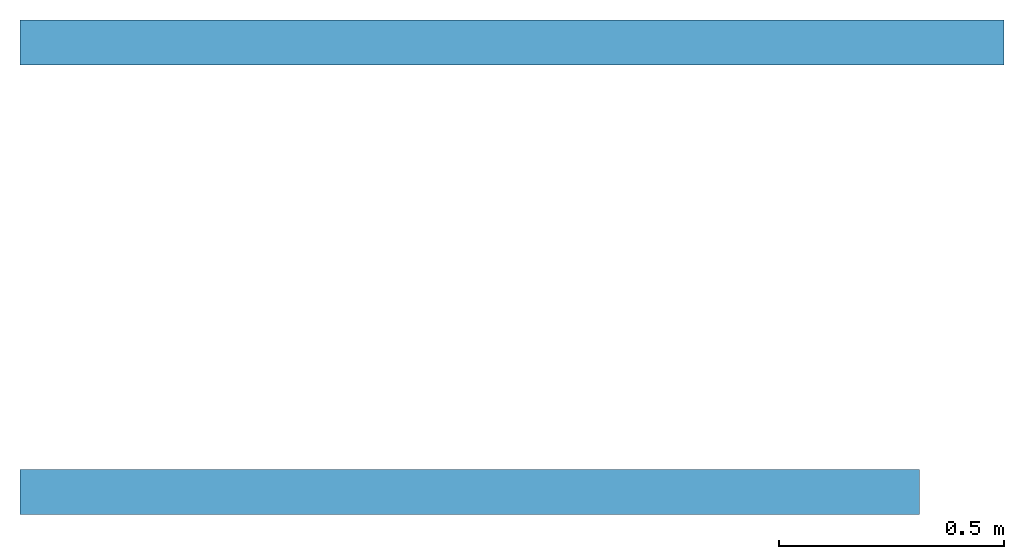
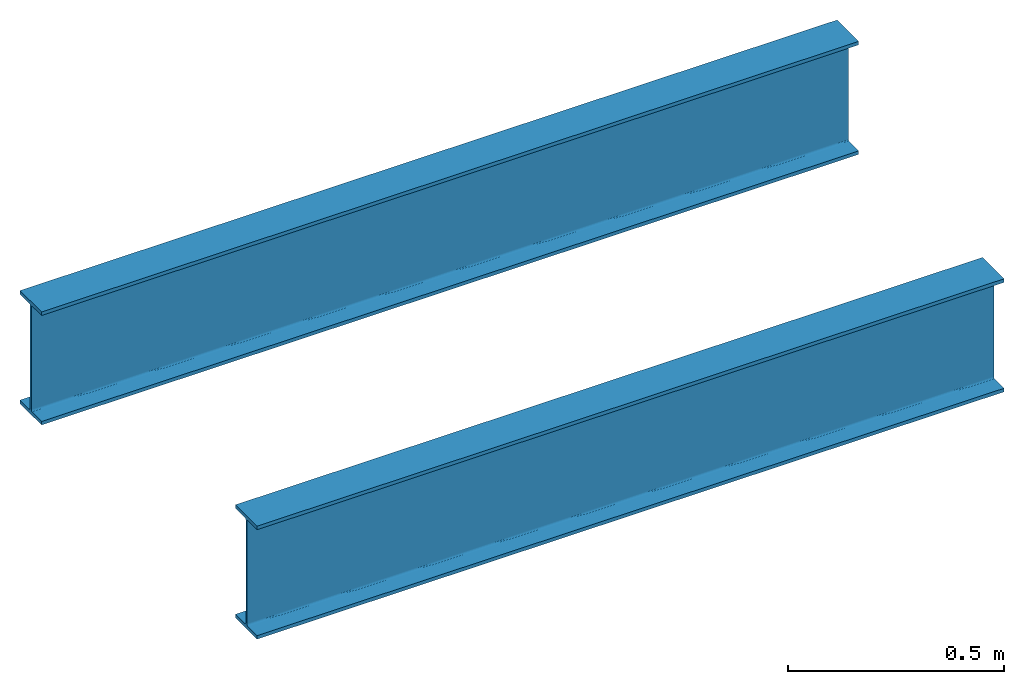
# One storey: 2 beams.
"""IFC4 building model written with IfcOpenShell, lengths in metres."""

from ifc_helpers import new_model, si_unit, frame, origin_with_axes, place, context, subcontext, project, spatial, i_section, extrude, material, material_profile, profile_set, profile_usage, type_object, element, save


model = new_model("IFC4")

# Units and contexts
model_context = context("Model", 3, precision=1e-05, world=origin_with_axes())
plan_context = context("Plan", 2, precision=1e-05, world=origin_with_axes())
body_context = subcontext(model_context, "Body", "Model", "MODEL_VIEW")
ifc_project = project(units=[si_unit("LENGTHUNIT", "METRE"), si_unit("AREAUNIT", "SQUARE_METRE"), si_unit("VOLUMEUNIT", "CUBIC_METRE")], contexts=[model_context, plan_context])

# Site, building, storey
site_placement = place(None, origin_with_axes())
site = spatial("IfcSite", under=ifc_project, at=site_placement)
building_placement = place(site_placement, origin_with_axes())
building = spatial("IfcBuilding", under=site, at=building_placement, Name="Building")
storey_placement = place(building_placement, origin_with_axes())
storey = spatial("IfcBuildingStorey", under=building, at=storey_placement, Name="Storey")

# Beams
ifc_material = material(Name="test material")
ifc_material_profile = material_profile(ifc_material, i_section(OverallWidth=0.100000001490116, OverallDepth=0.319999992847443, WebThickness=0.00499999988824129, FlangeThickness=0.00999999977648258, FilletRadius=0.00499999988824129))
ifc_profile_set = profile_set([ifc_material_profile])
ifc_profile_usage = profile_usage(ifc_profile_set)
beam_type = type_object("IfcBeamType", Name="DEMO1", material=ifc_profile_set)
beam_1_placement = place(storey_placement, frame((0.0, 0.0, 0.0), z_axis=(1.0, 4.37113882867379e-08, -4.37113882867379e-08), x_axis=(-4.37113882867379e-08, 1.0, 0.0)))
element("IfcBeam", 1, at=beam_1_placement, inside=storey, type_object=beam_type, material=ifc_profile_usage, Name="Beam", context=body_context, shape_type="SweptSolid", body=[
    extrude(i_section(OverallWidth=0.100000001490116, OverallDepth=0.319999992847443, WebThickness=0.00499999988824129, FlangeThickness=0.00999999977648258, FilletRadius=0.00499999988824129), None, (0.0, 0.0, 1.0), 2.0),
])
beam_2_placement = place(storey_placement, frame((-4.37113882867379e-08, 1.0, 0.0), z_axis=(1.0, 4.37113882867379e-08, -4.37113882867379e-08), x_axis=(-4.37113882867379e-08, 1.0, 0.0)))
element("IfcBeam", 2, at=beam_2_placement, inside=storey, type_object=beam_type, material=ifc_profile_usage, Name="Beam", context=body_context, shape_type="SweptSolid", body=[
    extrude(i_section(OverallWidth=0.100000001490116, OverallDepth=0.319999992847443, WebThickness=0.00499999988824129, FlangeThickness=0.00999999977648258, FilletRadius=0.00499999988824129), None, (0.0, 0.0, 1.0), 2.18797755241394),
])

save(model, "model.ifc")
